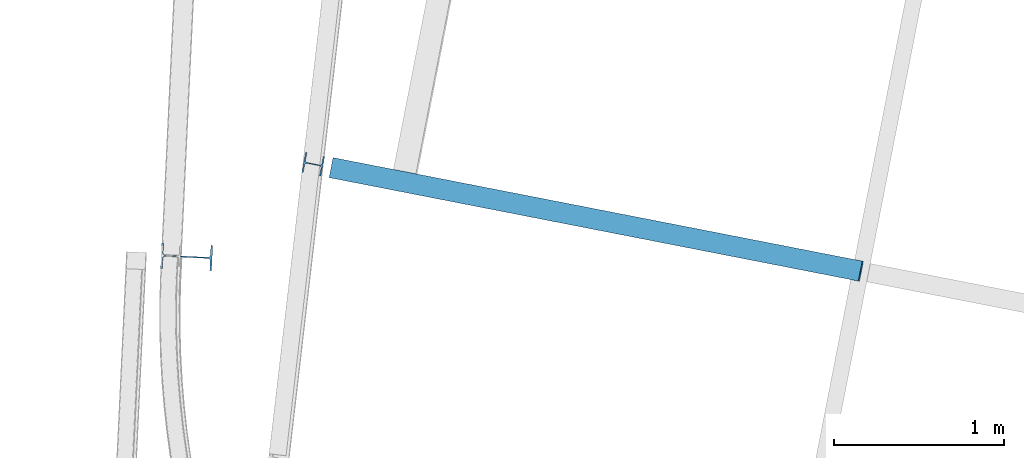
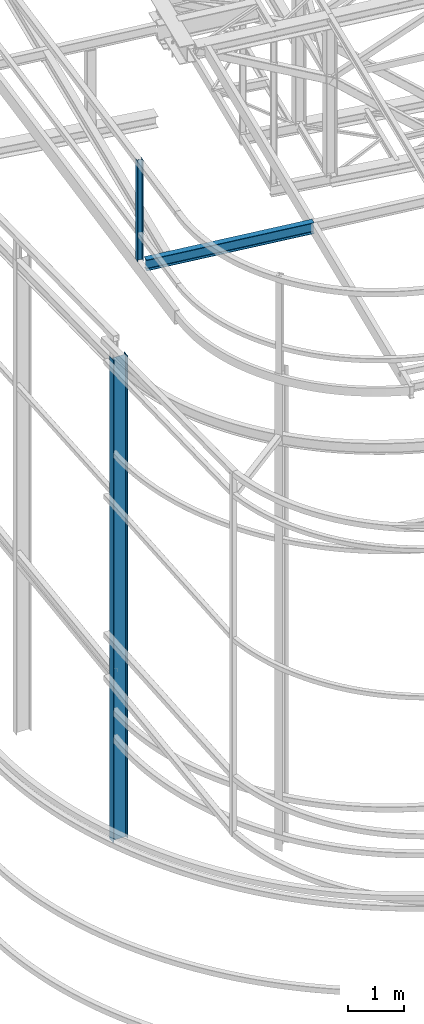
# One storey, part 39 of 215: 3 beams, 3 elements without a shape of their own.
"""IFC2X3 building model written with IfcOpenShell, lengths in millimetres."""

from ifc_helpers import new_model, si_unit, frame, origin_with_axes, origin_2d_with_axis, place, context, subcontext, project, spatial, i_section, extrude, material, type_object, element, aggregate, save


model = new_model("IFC2X3")

# Units and contexts
model_context = context("Model", 3, precision=1e-05, world=origin_with_axes())
body_context = subcontext(model_context, "Body", "Model", "MODEL_VIEW")
ifc_project = project(units=[si_unit("LENGTHUNIT", "METRE", prefix="MILLI"), si_unit("AREAUNIT", "SQUARE_METRE"), si_unit("VOLUMEUNIT", "CUBIC_METRE"), si_unit("MASSUNIT", "GRAM", prefix="KILO"), si_unit("TIMEUNIT", "SECOND"), si_unit("PLANEANGLEUNIT", "RADIAN"), si_unit("SOLIDANGLEUNIT", "STERADIAN"), si_unit("THERMODYNAMICTEMPERATUREUNIT", "DEGREE_CELSIUS"), si_unit("LUMINOUSINTENSITYUNIT", "LUMEN")], contexts=[model_context])

# Site, building, storey
site_placement = place(None, origin_with_axes())
site = spatial("IfcSite", under=ifc_project, at=site_placement, CompositionType="ELEMENT")
building_placement = place(site_placement, origin_with_axes())
building = spatial("IfcBuilding", under=site, at=building_placement, Name="Undefined", CompositionType="ELEMENT")
storey_placement = place(building_placement, origin_with_axes())
storey = spatial("IfcBuildingStorey", under=building, at=storey_placement, Name="Undefined", CompositionType="ELEMENT", Elevation=0.0)

# Assembly, beam
assembly_1_placement = place(storey_placement, origin_with_axes())
assembly_1 = element("IfcElementAssembly", 1, at=assembly_1_placement, inside=storey, Name="Steel Assembly", AssemblyPlace="NOTDEFINED", PredefinedType="RIGID_FRAME")
ifc_material = material(Name="STEEL/S275JR")
beam_type_1 = type_object("IfcBeamType", Name="IPE240", PredefinedType="NOTDEFINED")
beam_1_placement = place(assembly_1_placement, frame((38187.6570037252, 17087.098038685, 11919.2844535319), z_axis=(-0.0304080349967745, 0.00594450299936818, 0.999519891893966), x_axis=(0.980951223231219, -0.191767338045201, 0.0309836360073031)))
beam_1 = element("IfcBeam", 2, at=beam_1_placement, type_object=beam_type_1, material=ifc_material, Name="TRAVERSE", ObjectType="IPE240", context=body_context, shape_type="SweptSolid", body=[
    extrude(i_section(OverallWidth=120.0, OverallDepth=240.0, WebThickness=6.199999809, FlangeThickness=9.800000191, FilletRadius=15.0, at=origin_2d_with_axis()), frame((3171.99416009967, 3.60723736712668e-12, 3.65998893803246e-12), z_axis=(-1.0, 0.0, 0.0), x_axis=(-6.93889390390723e-18, -1.0, -3.46944695195361e-18)), (0.0, 0.0, 1.0), 3172.0),
])
aggregate(assembly_1, [beam_1])

assembly_2_placement = place(storey_placement, origin_with_axes())
assembly_2 = element("IfcElementAssembly", 3, at=assembly_2_placement, inside=storey, Name="Steel Assembly", AssemblyPlace="NOTDEFINED", PredefinedType="RIGID_FRAME")
beam_type_2 = type_object("IfcBeamType", Name="HEA120", PredefinedType="NOTDEFINED")
beam_2_placement = place(assembly_2_placement, frame((38079.1927415491, 17108.301878136, 14219.9969946526), z_axis=(0.981422409205525, -0.19185946604018, 1.89999991602007e-08), x_axis=(0.0, 0.0, -1.0)))
beam_2 = element("IfcBeam", 4, at=beam_2_placement, type_object=beam_type_2, material=ifc_material, ObjectType="HEA120", context=body_context, shape_type="SweptSolid", body=[
    extrude(i_section(OverallWidth=120.0, OverallDepth=114.0, WebThickness=5.0, FlangeThickness=8.0, FilletRadius=12.0, at=origin_2d_with_axis()), frame((2183.70126360292, 0.0, -7.22526139543954e-21), z_axis=(-1.0, 0.0, 0.0), x_axis=(-6.93889390390723e-18, -1.0, -3.46944695195361e-18)), (0.0, 0.0, 1.0), 2183.7),
])
aggregate(assembly_2, [beam_2])

assembly_3_placement = place(storey_placement, origin_with_axes())
assembly_3 = element("IfcElementAssembly", 5, at=assembly_3_placement, inside=storey, Name="Steel Assembly", AssemblyPlace="NOTDEFINED", PredefinedType="RIGID_FRAME")
beam_type_3 = type_object("IfcBeamType", Name="IPE300", PredefinedType="NOTDEFINED")
beam_3_placement = place(assembly_3_placement, frame((37334.7134470896, 16563.2282893329, 10526.2486998253), z_axis=(0.998866412658517, -0.0476013619837276, 0.0), x_axis=(0.0, 0.0, -1.0)))
beam_3 = element("IfcBeam", 6, at=beam_3_placement, type_object=beam_type_3, material=ifc_material, Name="MONTANT", ObjectType="IPE300", context=body_context, shape_type="SweptSolid", body=[
    extrude(i_section(OverallWidth=150.0, OverallDepth=300.0, WebThickness=7.099999905, FlangeThickness=10.69999981, FilletRadius=15.0, at=origin_2d_with_axis()), frame((10526.2486938997, 0.0, 0.0), z_axis=(-1.0, 0.0, 0.0), x_axis=(-6.93889390390723e-18, -1.0, -3.46944695195361e-18)), (0.0, 0.0, 1.0), 10526.2),
])
aggregate(assembly_3, [beam_3])

save(model, "model.ifc")
